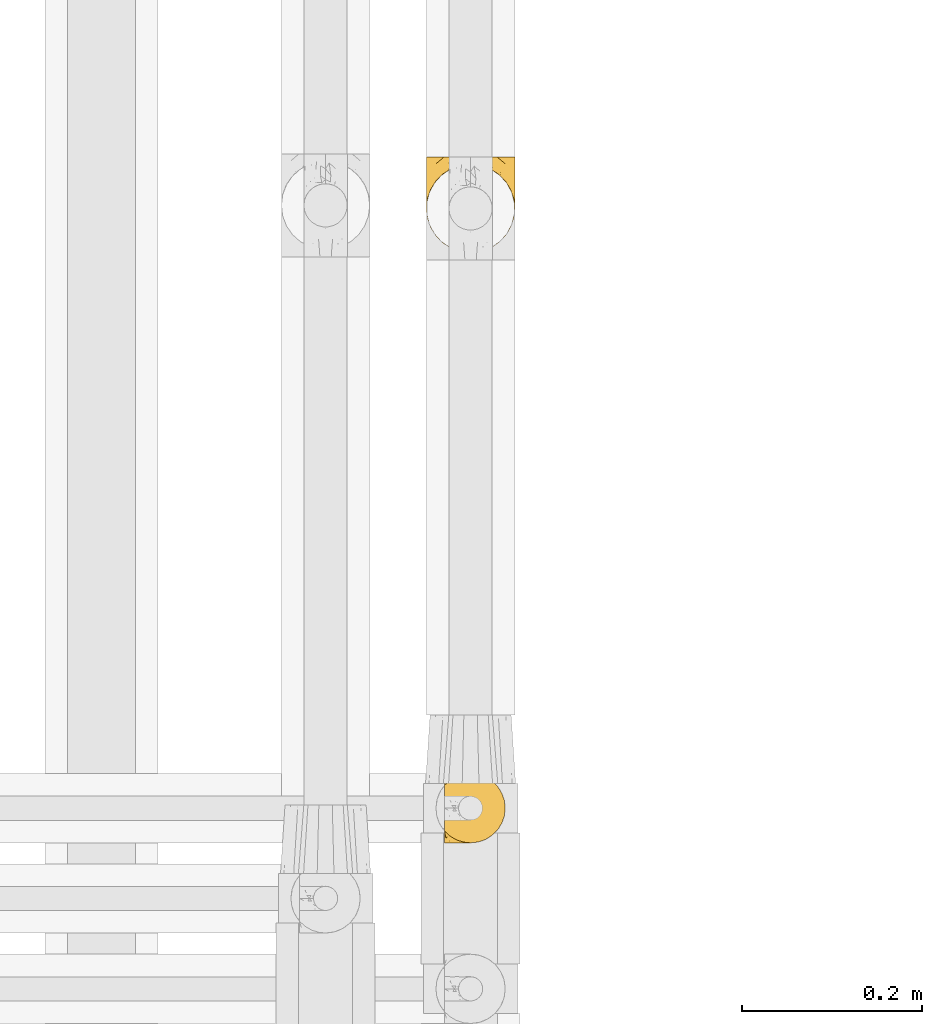
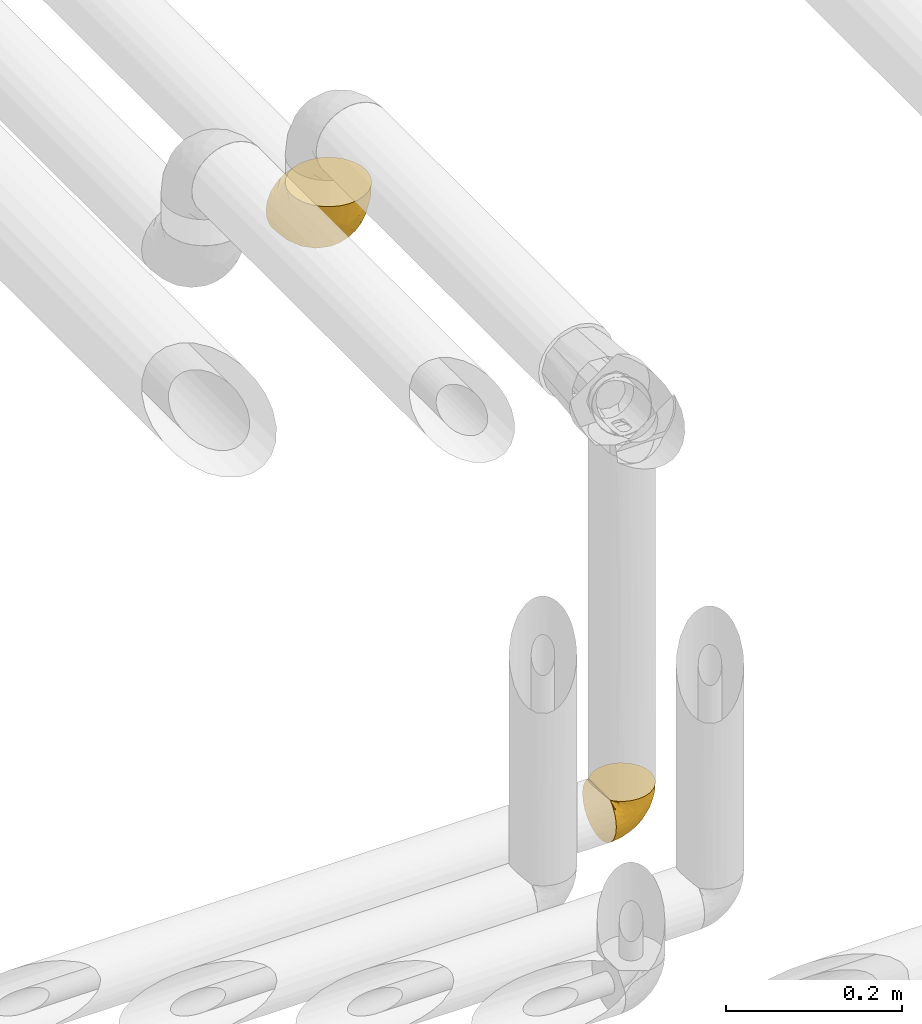
# One storey, part 346 of 827: 2 coverings.
"""IFC2X3 building model written with IfcOpenShell, lengths in millimetres."""

from ifc_helpers import new_model, entity, si_unit, converted_unit, derived_unit, direction, frame, origin, place, context, subcontext, project, spatial, faceted_brep, element, save


model = new_model("IFC2X3")

# Units and contexts
model_context = context("Model", 3, precision=0.01, world=origin(), true_north=direction((6.12303176911189e-17, 1.0)))
body_context = subcontext(model_context, "Body", "Model", "MODEL_VIEW")
ifc_project = project(units=[si_unit("LENGTHUNIT", "METRE", prefix="MILLI"), si_unit("AREAUNIT", "SQUARE_METRE"), si_unit("VOLUMEUNIT", "CUBIC_METRE"), converted_unit("PLANEANGLEUNIT", "DEGREE", entity("IfcRatioMeasure", 0.0174532925199433), si_unit("PLANEANGLEUNIT", "RADIAN"), dimensions=[0, 0, 0, 0, 0, 0, 0]), si_unit("MASSUNIT", "GRAM", prefix="KILO"), derived_unit("MASSDENSITYUNIT", [(si_unit("MASSUNIT", "GRAM", prefix="KILO"), 1), (si_unit("LENGTHUNIT", "METRE"), -3)]), derived_unit("MOMENTOFINERTIAUNIT", [(si_unit("LENGTHUNIT", "METRE"), 4)]), si_unit("TIMEUNIT", "SECOND"), si_unit("FREQUENCYUNIT", "HERTZ"), si_unit("THERMODYNAMICTEMPERATUREUNIT", "DEGREE_CELSIUS"), derived_unit("THERMALTRANSMITTANCEUNIT", [(si_unit("MASSUNIT", "GRAM", prefix="KILO"), 1), (si_unit("THERMODYNAMICTEMPERATUREUNIT", "KELVIN"), -1), (si_unit("TIMEUNIT", "SECOND"), -3)]), derived_unit("VOLUMETRICFLOWRATEUNIT", [(si_unit("LENGTHUNIT", "METRE"), 3), (si_unit("TIMEUNIT", "SECOND"), -1)]), derived_unit("MASSFLOWRATEUNIT", [(si_unit("MASSUNIT", "GRAM", prefix="KILO"), 1), (si_unit("TIMEUNIT", "SECOND"), -1)]), derived_unit("ROTATIONALFREQUENCYUNIT", [(si_unit("TIMEUNIT", "SECOND"), -1)]), si_unit("ELECTRICCURRENTUNIT", "AMPERE"), si_unit("ELECTRICVOLTAGEUNIT", "VOLT"), si_unit("POWERUNIT", "WATT"), si_unit("FORCEUNIT", "NEWTON", prefix="KILO"), si_unit("ILLUMINANCEUNIT", "LUX"), si_unit("LUMINOUSFLUXUNIT", "LUMEN"), si_unit("LUMINOUSINTENSITYUNIT", "CANDELA"), derived_unit("USERDEFINED", [(si_unit("MASSUNIT", "GRAM", prefix="KILO"), -1), (si_unit("LENGTHUNIT", "METRE"), -2), (si_unit("TIMEUNIT", "SECOND"), 3), (si_unit("LUMINOUSFLUXUNIT", "LUMEN"), 1)]), derived_unit("LINEARVELOCITYUNIT", [(si_unit("LENGTHUNIT", "METRE"), 1), (si_unit("TIMEUNIT", "SECOND"), -1)]), si_unit("PRESSUREUNIT", "PASCAL"), derived_unit("USERDEFINED", [(si_unit("LENGTHUNIT", "METRE"), -2), (si_unit("MASSUNIT", "GRAM", prefix="KILO"), 1), (si_unit("TIMEUNIT", "SECOND"), -2)]), derived_unit("LINEARFORCEUNIT", [(si_unit("MASSUNIT", "GRAM", prefix="KILO"), 1), (si_unit("LENGTHUNIT", "METRE"), 1), (si_unit("TIMEUNIT", "SECOND"), -2), (si_unit("LENGTHUNIT", "METRE"), -1)]), derived_unit("PLANARFORCEUNIT", [(si_unit("MASSUNIT", "GRAM", prefix="KILO"), 1), (si_unit("LENGTHUNIT", "METRE"), 1), (si_unit("TIMEUNIT", "SECOND"), -2), (si_unit("LENGTHUNIT", "METRE"), -2)])], contexts=[model_context])

# Site, building, storey
site_placement = place(None, origin())
site = spatial("IfcSite", under=ifc_project, at=site_placement, CompositionType="ELEMENT")
building_placement = place(site_placement, origin())
building = spatial("IfcBuilding", under=site, at=building_placement, CompositionType="ELEMENT")
storey_placement = place(building_placement, frame((0.0, 0.0, 28200.0)))
storey = spatial("IfcBuildingStorey", under=building, at=storey_placement, Name="08", CompositionType="ELEMENT", Elevation=28200.0)

# Coverings
covering_1_placement = place(storey_placement, frame((36598.95, 15549.99, 2959.95)))
element("IfcCovering", 1, at=covering_1_placement, inside=storey, Name=":ADSK_", ObjectType=":ADSK_", PredefinedType="INSULATION", context=body_context, shape_type="Brep", body=[
    faceted_brep([(47.38, 5.41, 69.15), (54.67, 9.99, 69.15), (60.76, 16.08, 69.15), (65.34, 23.37, 69.15), (68.18, 31.49, 69.15), (69.15, 40.05, 69.15), (68.18, 48.61, 69.15), (65.33, 56.73, 69.15), (60.75, 64.02, 69.15), (54.66, 70.11, 69.15), (47.37, 74.69, 69.15), (39.25, 77.53, 69.15), (30.7, 78.5, 69.15), (22.59, 77.63, 69.15), (14.86, 75.08, 69.15), (7.84, 70.97, 69.15), (1.85, 65.47, 69.15), (1.85, 63.27, 69.15), (1.85, 61.53, 69.15), (1.85, 59.57, 69.15), (1.85, 57.6, 69.15), (1.85, 55.63, 69.15), (1.85, 53.67, 69.15), (1.85, 51.7, 69.15), (1.85, 49.73, 69.15), (1.85, 47.54, 69.15), (1.85, 45.34, 69.15), (1.85, 43.15, 69.15), (1.85, 40.96, 69.15), (1.85, 38.76, 69.15), (1.85, 36.57, 69.15), (1.85, 34.37, 69.15), (1.85, 32.18, 69.15), (1.85, 29.98, 69.15), (1.85, 27.79, 69.15), (1.85, 25.6, 69.15), (1.85, 23.4, 69.15), (1.85, 21.21, 69.15), (1.85, 19.01, 69.15), (1.85, 16.82, 69.15), (1.85, 14.62, 69.15), (7.85, 9.12, 69.15), (14.88, 5.0, 69.15), (22.61, 2.46, 69.15), (30.7, 1.6, 69.15), (39.26, 2.56, 69.15), (1.6, 65.47, 68.89), (1.6, 70.97, 62.89), (1.6, 75.09, 55.87), (1.6, 77.63, 48.14), (1.6, 78.5, 40.05), (1.6, 77.19, 30.09), (1.6, 73.34, 20.82), (1.6, 67.23, 12.86), (1.6, 59.27, 6.75), (1.6, 50.0, 2.91), (1.6, 40.05, 1.6), (1.6, 30.09, 2.91), (1.6, 20.82, 6.75), (1.6, 12.86, 12.86), (1.6, 6.75, 20.82), (1.6, 2.91, 30.09), (1.6, 1.6, 40.05), (1.6, 2.46, 48.14), (1.6, 5.0, 55.87), (1.6, 9.12, 62.89), (1.6, 14.62, 68.89), (1.6, 16.82, 68.89), (1.6, 17.8, 68.89), (1.6, 19.39, 68.89), (1.6, 20.98, 68.89), (1.6, 22.57, 68.89), (1.6, 24.16, 68.89), (1.6, 25.75, 68.89), (1.6, 27.33, 68.89), (1.6, 28.92, 68.89), (1.6, 30.51, 68.89), (1.6, 32.1, 68.89), (1.6, 33.69, 68.89), (1.6, 35.28, 68.89), (1.6, 36.87, 68.89), (1.6, 38.46, 68.89), (1.6, 40.05, 68.89), (1.6, 41.63, 68.89), (1.6, 43.22, 68.89), (1.6, 44.81, 68.89), (1.6, 46.4, 68.89), (1.6, 47.99, 68.89), (1.6, 49.58, 68.89), (1.6, 51.17, 68.89), (1.6, 52.76, 68.89), (1.6, 54.72, 68.89), (1.6, 56.69, 68.89), (1.6, 58.88, 68.89), (1.6, 61.08, 68.89), (1.6, 63.27, 68.89), (1.78, 37.77, 68.97), (1.77, 36.07, 68.96), (1.78, 32.96, 68.97), (1.77, 31.36, 68.97), (1.79, 56.52, 68.98), (1.78, 54.96, 68.97), (1.76, 18.75, 68.96), (1.77, 58.07, 68.96), (1.77, 50.37, 68.96), (1.76, 23.36, 68.96), (1.77, 24.95, 68.96), (1.77, 42.43, 68.96), (1.8, 15.97, 69.0), (1.76, 51.96, 68.96), (1.77, 53.47, 68.96), (1.78, 48.63, 68.97), (1.77, 63.93, 68.96), (1.77, 40.93, 68.96), (1.76, 29.72, 68.96), (1.77, 62.4, 68.97), (1.78, 60.92, 68.97), (1.77, 17.31, 68.97), (1.77, 21.74, 68.96), (1.77, 34.56, 68.96), (1.78, 20.18, 68.97), (1.77, 14.62, 68.97), (1.8, 14.62, 69.02), (1.82, 14.62, 69.08), (1.77, 65.47, 68.97), (1.72, 65.47, 68.94), (1.66, 65.47, 68.92), (1.76, 59.5, 68.96), (1.77, 47.1, 68.96), (1.76, 45.61, 68.95), (1.77, 28.18, 68.96), (1.66, 14.62, 68.92), (1.72, 14.62, 68.94), (1.78, 26.61, 68.98), (1.82, 65.47, 69.08), (1.8, 65.47, 69.02), (1.77, 39.32, 68.96), (1.78, 44.12, 68.97), (3.72, 72.26, 61.33), (7.41, 76.57, 53.1), (6.13, 71.77, 63.33), (21.47, 78.5, 49.27), (19.34, 77.9, 55.53), (26.8, 78.5, 54.6), (8.87, 78.5, 41.99), (9.2, 75.52, 57.07), (12.79, 76.13, 57.95), (14.62, 77.81, 51.56), (7.34, 78.5, 41.58), (5.33, 72.4, 61.7), (17.64, 76.56, 63.33), (7.7, 71.77, 65.0), (9.41, 72.25, 67.02), (28.75, 78.5, 61.87), (16.15, 78.5, 43.94), (14.14, 75.75, 61.21), (29.16, 78.5, 63.4), (57.02, 50.46, 33.11), (64.92, 52.75, 52.82), (64.0, 40.05, 43.3), (11.92, 77.7, 33.73), (19.16, 77.66, 36.52), (28.65, 71.02, 24.87), (24.62, 63.45, 14.17), (15.19, 70.55, 18.43), (18.36, 75.57, 28.67), (9.2, 75.57, 26.0), (46.98, 72.61, 49.25), (50.24, 72.61, 59.72), (56.1, 67.24, 55.1), (28.97, 77.74, 44.72), (54.46, 57.43, 34.15), (21.34, 47.19, 5.25), (18.4, 54.76, 6.75), (66.44, 40.05, 55.54), (12.07, 63.45, 10.47), (45.49, 60.1, 25.49), (50.57, 63.72, 35.53), (36.04, 76.83, 48.22), (42.07, 76.34, 58.71), (62.12, 60.51, 57.42), (37.37, 72.59, 34.84), (29.39, 76.05, 36.87), (53.59, 66.15, 45.01), (58.06, 60.51, 44.4), (49.27, 51.88, 23.96), (29.63, 55.34, 11.2), (33.21, 48.67, 10.56), (40.1, 53.89, 16.81), (44.08, 46.73, 17.38), (49.36, 40.05, 21.38), (56.68, 40.05, 32.34), (15.2, 40.05, 4.3), (35.57, 63.95, 20.65), (41.7, 67.24, 29.66), (46.4, 69.62, 39.6), (41.41, 73.6, 42.55), (27.45, 40.05, 6.74), (38.4, 40.05, 14.06), (12.99, 4.52, 26.84), (21.33, 32.72, 5.28), (42.89, 27.18, 18.52), (57.04, 29.63, 33.13), (56.11, 12.86, 55.1), (62.13, 19.59, 57.43), (21.89, 9.54, 20.72), (16.62, 16.64, 11.46), (32.9, 17.48, 17.69), (46.99, 7.49, 49.26), (50.25, 7.49, 59.73), (42.08, 3.75, 58.71), (49.91, 20.75, 29.72), (15.6, 2.33, 35.35), (16.15, 1.6, 43.94), (8.87, 1.6, 41.99), (29.16, 1.6, 63.4), (13.16, 26.94, 4.93), (10.83, 9.54, 17.46), (33.8, 31.21, 10.94), (25.02, 25.33, 8.92), (64.92, 27.35, 52.83), (32.83, 8.17, 29.34), (20.56, 4.3, 30.26), (58.07, 19.59, 44.4), (21.46, 2.23, 39.06), (28.1, 2.45, 43.06), (26.8, 1.6, 54.6), (21.47, 1.6, 49.27), (51.29, 12.86, 42.69), (36.04, 3.27, 48.2), (28.75, 1.6, 61.87), (8.45, 2.29, 33.44), (41.73, 12.86, 29.67), (39.27, 6.89, 38.5), (33.56, 12.43, 23.35), (27.29, 4.1, 34.97), (7.41, 3.53, 53.1), (3.51, 6.88, 59.68), (4.68, 8.16, 62.19), (5.52, 9.02, 64.11), (8.75, 5.0, 57.97), (12.79, 3.96, 57.95), (17.65, 3.52, 63.33), (13.9, 2.4, 51.77), (9.42, 7.83, 67.02), (7.68, 8.32, 64.98), (19.33, 2.19, 55.53), (14.13, 4.34, 61.22)], [[[0, 1, 2, 3, 4, 5, 6, 7, 8, 9, 10, 11, 12, 13, 14, 15, 16, 17, 18, 19, 20, 21, 22, 23, 24, 25, 26, 27, 28, 29, 30, 31, 32, 33, 34, 35, 36, 37, 38, 39, 40, 41, 42, 43, 44, 45]], [[46, 47, 48, 49, 50, 51, 52, 53, 54, 55, 56, 57, 58, 59, 60, 61, 62, 63, 64, 65, 66, 67, 68, 69, 70, 71, 72, 73, 74, 75, 76, 77, 78, 79, 80, 81, 82, 83, 84, 85, 86, 87, 88, 89, 90, 91, 92, 93, 94, 95]], [[96, 97, 30]], [[98, 77, 99]], [[100, 101, 21]], [[69, 68, 102]], [[20, 19, 103]], [[24, 23, 104]], [[20, 103, 100]], [[72, 105, 106]], [[84, 83, 107]], [[89, 88, 104]], [[108, 67, 66]], [[109, 110, 90]], [[111, 25, 24]], [[112, 17, 16]], [[82, 113, 83]], [[109, 23, 22]], [[114, 76, 75]], [[105, 36, 106]], [[104, 111, 24]], [[18, 115, 116]], [[97, 96, 80]], [[67, 108, 117]], [[105, 71, 118]], [[31, 97, 119]], [[102, 120, 69]], [[108, 121, 122, 123, 40]], [[112, 95, 115]], [[17, 115, 18]], [[94, 116, 115]], [[117, 68, 67]], [[38, 117, 39]], [[112, 124, 125, 126, 46]], [[17, 112, 115]], [[70, 120, 118]], [[39, 117, 108]], [[120, 38, 37]], [[120, 37, 118]], [[120, 70, 69]], [[116, 94, 127]], [[128, 86, 129]], [[117, 38, 102]], [[74, 130, 75]], [[99, 33, 32]], [[115, 95, 94]], [[39, 108, 40]], [[108, 66, 131, 132, 121]], [[105, 72, 71]], [[118, 37, 36]], [[71, 70, 118]], [[35, 106, 36]], [[36, 105, 118]], [[35, 133, 106]], [[74, 73, 133]], [[106, 133, 73]], [[99, 114, 33]], [[133, 35, 34]], [[73, 72, 106]], [[95, 112, 46]], [[112, 16, 134, 135, 124]], [[130, 114, 75]], [[99, 76, 114]], [[114, 130, 33]], [[34, 33, 130]], [[78, 77, 98]], [[98, 119, 78]], [[130, 133, 34]], [[133, 130, 74]], [[79, 97, 80]], [[98, 99, 32]], [[98, 32, 31]], [[77, 76, 99]], [[97, 79, 119]], [[136, 96, 29]], [[30, 97, 31]], [[136, 29, 28]], [[81, 80, 96]], [[29, 96, 30]], [[31, 119, 98]], [[119, 79, 78]], [[96, 136, 81]], [[82, 81, 136]], [[113, 107, 83]], [[84, 107, 137]], [[107, 27, 137]], [[113, 28, 107]], [[27, 107, 28]], [[85, 84, 137]], [[137, 27, 26]], [[113, 136, 28]], [[136, 113, 82]], [[109, 89, 104]], [[86, 85, 129]], [[89, 109, 90]], [[111, 87, 128]], [[26, 129, 137]], [[88, 111, 104]], [[25, 111, 128]], [[22, 110, 109]], [[23, 109, 104]], [[110, 91, 90]], [[100, 92, 101]], [[110, 22, 101]], [[91, 110, 101]], [[116, 19, 18]], [[111, 88, 87]], [[127, 103, 19]], [[25, 128, 26]], [[86, 128, 87]], [[128, 129, 26]], [[137, 129, 85]], [[120, 102, 38]], [[117, 102, 68]], [[91, 101, 92]], [[21, 101, 22]], [[93, 92, 103]], [[100, 21, 20]], [[100, 103, 92]], [[127, 93, 103]], [[93, 127, 94]], [[116, 127, 19]], [[126, 138, 47]], [[48, 138, 139]], [[140, 125, 124]], [[141, 142, 143]], [[144, 49, 139]], [[145, 140, 146]], [[48, 139, 49]], [[139, 145, 147]], [[49, 144, 148, 50]], [[126, 125, 149]], [[14, 13, 150]], [[151, 146, 140]], [[149, 140, 145]], [[152, 151, 135]], [[152, 14, 150]], [[16, 15, 134]], [[13, 153, 150]], [[124, 151, 140]], [[141, 147, 142]], [[14, 152, 15]], [[15, 152, 134]], [[47, 46, 126]], [[139, 154, 144]], [[138, 48, 47]], [[125, 140, 149]], [[135, 134, 152]], [[146, 155, 142]], [[145, 146, 147]], [[149, 139, 138]], [[147, 141, 154]], [[147, 146, 142]], [[139, 147, 154]], [[139, 149, 145]], [[149, 138, 126]], [[155, 146, 151]], [[150, 143, 142]], [[152, 155, 151]], [[150, 142, 155]], [[13, 12, 156, 153]], [[153, 143, 150]], [[152, 150, 155]], [[151, 124, 135]], [[157, 158, 159]], [[160, 154, 161]], [[162, 163, 164]], [[165, 166, 160]], [[167, 168, 169]], [[141, 170, 161]], [[156, 12, 11]], [[158, 157, 171]], [[172, 55, 173]], [[158, 6, 174]], [[175, 54, 53]], [[52, 166, 164]], [[52, 164, 53]], [[54, 175, 173]], [[166, 52, 51]], [[176, 177, 171]], [[178, 143, 179]], [[156, 11, 179]], [[8, 7, 180]], [[169, 9, 8]], [[179, 143, 153, 156]], [[179, 11, 10]], [[168, 179, 10]], [[181, 162, 182]], [[179, 167, 178]], [[183, 184, 177]], [[183, 169, 184]], [[176, 171, 185]], [[172, 186, 187]], [[158, 7, 6]], [[159, 158, 174]], [[184, 180, 158]], [[54, 173, 55]], [[180, 169, 8]], [[188, 189, 187]], [[9, 168, 10]], [[186, 188, 187]], [[190, 157, 159, 191]], [[55, 172, 192]], [[176, 193, 194]], [[161, 170, 182]], [[162, 164, 165]], [[175, 164, 163]], [[51, 50, 148]], [[167, 195, 196]], [[178, 182, 170]], [[6, 5, 174]], [[158, 180, 7]], [[169, 180, 184]], [[169, 168, 9]], [[179, 168, 167]], [[182, 162, 165]], [[162, 194, 193]], [[161, 165, 160]], [[195, 181, 196]], [[192, 172, 197]], [[192, 56, 55]], [[189, 190, 198]], [[198, 197, 187]], [[172, 187, 197]], [[185, 189, 188]], [[198, 187, 189]], [[186, 172, 173]], [[173, 163, 186]], [[193, 186, 163]], [[176, 185, 188]], [[185, 157, 190]], [[188, 186, 193]], [[177, 176, 194]], [[188, 193, 176]], [[162, 193, 163]], [[195, 177, 194]], [[171, 177, 184]], [[181, 195, 194]], [[183, 167, 169]], [[162, 181, 194]], [[196, 182, 178]], [[158, 171, 184]], [[171, 157, 185]], [[177, 195, 183]], [[167, 183, 195]], [[182, 196, 181]], [[178, 170, 143]], [[178, 167, 196]], [[164, 175, 53]], [[173, 175, 163]], [[160, 51, 148]], [[164, 166, 165]], [[51, 160, 166]], [[160, 148, 144, 154]], [[141, 161, 154]], [[182, 165, 161]], [[190, 189, 185]], [[143, 170, 141]], [[60, 199, 61]], [[197, 200, 192]], [[201, 190, 202]], [[200, 57, 192]], [[203, 204, 2]], [[205, 206, 207]], [[208, 209, 210]], [[211, 207, 201]], [[212, 213, 214]], [[45, 215, 210]], [[216, 206, 58]], [[45, 44, 215]], [[59, 217, 60]], [[60, 217, 199]], [[0, 45, 210]], [[218, 201, 219]], [[202, 159, 220]], [[205, 221, 222]], [[223, 204, 203]], [[1, 203, 2]], [[57, 200, 216]], [[220, 3, 204]], [[220, 174, 4]], [[1, 0, 209]], [[212, 224, 213]], [[225, 226, 227]], [[228, 223, 203]], [[208, 210, 229]], [[210, 226, 229]], [[3, 220, 4]], [[58, 206, 59]], [[209, 203, 1]], [[202, 220, 223]], [[228, 203, 208]], [[202, 211, 201]], [[3, 2, 204]], [[202, 190, 191, 159]], [[210, 215, 230, 226]], [[199, 212, 231]], [[232, 233, 221]], [[233, 208, 229]], [[207, 206, 219]], [[217, 206, 205]], [[227, 224, 225]], [[233, 232, 228]], [[201, 207, 219]], [[234, 232, 221]], [[218, 219, 200]], [[202, 223, 211]], [[174, 220, 159]], [[174, 5, 4]], [[61, 231, 62]], [[220, 204, 223]], [[210, 209, 0]], [[203, 209, 208]], [[225, 233, 229]], [[224, 227, 213]], [[221, 233, 235]], [[57, 56, 192]], [[198, 218, 197]], [[200, 219, 216]], [[201, 198, 190]], [[197, 218, 200]], [[198, 201, 218]], [[206, 216, 219]], [[58, 57, 216]], [[231, 212, 214]], [[222, 212, 199]], [[228, 211, 223]], [[207, 211, 232]], [[62, 231, 214]], [[199, 231, 61]], [[233, 228, 208]], [[211, 228, 232]], [[222, 221, 235]], [[234, 205, 207]], [[206, 217, 59]], [[199, 217, 205]], [[205, 222, 199]], [[224, 222, 235]], [[222, 224, 212]], [[224, 235, 225]], [[233, 225, 235]], [[226, 225, 229]], [[205, 234, 221]], [[207, 232, 234]], [[63, 214, 236]], [[214, 213, 236]], [[214, 63, 62]], [[237, 236, 238]], [[238, 132, 131]], [[236, 237, 64]], [[239, 240, 241]], [[63, 236, 64]], [[131, 66, 65]], [[237, 131, 65]], [[242, 230, 43]], [[237, 65, 64]], [[239, 121, 132]], [[42, 242, 43]], [[241, 240, 243]], [[41, 123, 244]], [[43, 230, 215, 44]], [[244, 122, 245]], [[227, 246, 243]], [[241, 247, 245]], [[121, 239, 245]], [[41, 40, 123]], [[132, 238, 239]], [[244, 42, 41]], [[131, 237, 238]], [[240, 239, 238]], [[245, 239, 241]], [[247, 241, 246]], [[247, 244, 245]], [[238, 236, 240]], [[243, 236, 213]], [[236, 243, 240]], [[227, 226, 246]], [[243, 213, 227]], [[242, 246, 226]], [[243, 246, 241]], [[246, 242, 247]], [[244, 247, 242]], [[242, 226, 230]], [[42, 244, 242]], [[122, 244, 123]], [[122, 121, 245]]]),
])
covering_2_placement = place(storey_placement, frame((36578.9, 16204.74, 3349.15)))
element("IfcCovering", 2, at=covering_2_placement, inside=storey, Name=":ADSK_", ObjectType=":ADSK_", PredefinedType="INSULATION", context=body_context, shape_type="Brep", body=[
    faceted_brep([(1.6, 50.75, 107.75), (2.83, 39.8, 107.75), (6.47, 29.41, 107.75), (12.32, 20.09, 107.75), (20.11, 12.31, 107.75), (29.43, 6.46, 107.75), (39.81, 2.83, 107.75), (50.75, 1.6, 107.75), (61.69, 2.83, 107.75), (72.08, 6.47, 107.75), (81.4, 12.32, 107.75), (89.18, 20.11, 107.75), (95.03, 29.43, 107.75), (98.66, 39.81, 107.75), (99.9, 50.75, 107.75), (99.25, 56.45, 107.75), (98.66, 61.69, 107.75), (96.84, 66.88, 107.75), (95.02, 72.08, 107.75), (89.17, 81.4, 107.75), (81.38, 89.18, 107.75), (72.06, 95.03, 107.75), (61.68, 98.66, 107.75), (50.75, 99.9, 107.75), (39.8, 98.66, 107.75), (29.41, 95.02, 107.75), (20.09, 89.17, 107.75), (12.31, 81.38, 107.75), (6.46, 72.06, 107.75), (4.64, 66.87, 107.75), (2.83, 61.68, 107.75), (2.24, 56.45, 107.75), (1.92, 53.6, 107.75), (63.47, 107.75, 98.22), (75.32, 107.75, 93.31), (80.41, 107.75, 89.4), (85.5, 107.75, 85.5), (89.4, 107.75, 80.41), (93.31, 107.75, 75.32), (95.77, 107.75, 69.39), (98.22, 107.75, 63.47), (99.14, 107.75, 56.48), (99.52, 107.75, 53.61), (99.9, 107.75, 50.75), (98.22, 107.75, 38.02), (93.31, 107.75, 26.17), (85.5, 107.75, 15.99), (75.32, 107.75, 8.18), (63.47, 107.75, 3.27), (50.75, 107.75, 1.6), (38.02, 107.75, 3.27), (26.17, 107.75, 8.18), (15.99, 107.75, 15.99), (8.18, 107.75, 26.17), (3.27, 107.75, 38.02), (1.6, 107.75, 50.75), (2.35, 107.75, 56.48), (3.27, 107.75, 63.47), (5.73, 107.75, 69.39), (8.18, 107.75, 75.32), (12.09, 107.75, 80.41), (15.99, 107.75, 85.5), (21.08, 107.75, 89.4), (26.17, 107.75, 93.31), (38.02, 107.75, 98.22), (50.75, 107.75, 99.9), (42.18, 39.38, 27.53), (28.42, 49.75, 25.32), (37.78, 57.38, 16.29), (50.75, 74.94, 6.79), (42.85, 85.97, 4.51), (50.75, 95.66, 3.51), (24.75, 67.82, 17.47), (33.81, 83.09, 7.6), (22.57, 89.16, 12.27), (7.18, 37.01, 70.89), (2.73, 43.46, 87.17), (3.09, 51.79, 67.3), (6.92, 85.58, 31.65), (11.58, 62.84, 33.58), (5.17, 62.77, 47.23), (2.71, 88.17, 43.26), (1.6, 85.93, 55.08), (1.6, 91.42, 53.99), (1.6, 96.91, 52.9), (1.6, 99.62, 52.36), (1.6, 102.33, 51.82), (14.18, 82.57, 21.5), (5.88, 32.75, 89.94), (41.06, 13.79, 60.45), (36.25, 6.77, 83.0), (28.62, 16.46, 64.79), (1.6, 55.08, 85.93), (1.6, 58.17, 81.31), (1.6, 61.26, 76.69), (1.6, 64.35, 72.06), (1.6, 67.44, 67.44), (10.85, 24.18, 88.74), (38.35, 23.37, 45.98), (9.6, 49.76, 47.13), (26.24, 9.84, 89.4), (50.75, 3.51, 95.66), (19.31, 55.75, 28.5), (16.41, 42.34, 42.81), (24.56, 37.78, 38.28), (50.75, 21.87, 45.35), (50.75, 33.61, 33.61), (18.47, 17.1, 82.57), (1.6, 51.28, 105.04), (1.6, 51.82, 102.33), (1.6, 52.9, 96.91), (1.6, 53.99, 91.42), (14.36, 28.01, 65.92), (20.64, 28.99, 53.11), (2.32, 69.9, 54.37), (50.75, 6.79, 74.94), (1.6, 72.06, 64.35), (1.6, 76.69, 61.26), (1.6, 81.31, 58.17), (50.75, 45.35, 21.87), (33.88, 34.79, 34.79), (29.24, 25.72, 48.48), (50.75, 14.33, 60.15), (50.75, 60.15, 14.33), (2.8, 62.38, 99.07), (2.48, 100.57, 60.55), (2.7, 91.06, 64.18), (3.2, 97.66, 64.36), (32.98, 97.55, 103.17), (24.67, 93.65, 101.69), (2.95, 66.85, 87.75), (2.19, 61.93, 89.38), (17.92, 101.4, 88.34), (12.02, 100.07, 82.14), (25.73, 101.36, 94.51), (16.63, 95.94, 89.64), (25.6, 96.3, 98.41), (36.72, 101.98, 99.71), (10.66, 85.88, 89.37), (6.87, 78.88, 88.21), (11.12, 82.8, 95.2), (10.31, 102.58, 79.14), (12.84, 82.88, 101.22), (17.38, 88.57, 99.41), (9.74, 88.67, 84.72), (4.63, 69.08, 97.47), (50.75, 102.19, 102.19), (42.52, 100.06, 104.02), (3.12, 70.56, 82.66), (17.58, 91.07, 95.42), (3.97, 77.56, 78.67), (5.94, 96.59, 72.69), (2.73, 86.38, 66.46), (6.23, 91.79, 75.3), (3.45, 81.71, 72.74), (10.84, 94.11, 82.93), (7.98, 76.09, 99.27), (7.33, 76.91, 93.51), (2.39, 81.44, 67.35), (75.76, 101.37, 94.51), (90.65, 94.12, 82.94), (83.57, 101.41, 88.33), (84.85, 95.96, 89.64), (71.05, 96.22, 103.62), (98.54, 66.85, 87.74), (99.3, 61.94, 89.38), (99.9, 58.17, 81.31), (96.86, 69.1, 97.47), (84.1, 88.58, 99.41), (99.9, 96.91, 52.9), (99.9, 102.33, 51.82), (99.9, 105.04, 51.28), (88.63, 82.9, 101.21), (90.36, 82.82, 95.19), (98.29, 97.66, 64.36), (95.55, 96.59, 72.69), (89.47, 100.07, 82.13), (95.26, 91.79, 75.3), (91.18, 102.58, 79.14), (93.49, 76.13, 99.28), (94.15, 76.93, 93.51), (99.01, 100.57, 60.55), (98.76, 86.38, 66.46), (98.85, 90.86, 63.96), (99.9, 52.9, 96.91), (98.69, 62.39, 99.06), (64.78, 101.98, 99.7), (99.9, 91.42, 53.99), (99.9, 85.93, 55.08), (62.91, 99.49, 103.3), (99.9, 51.82, 102.33), (99.9, 52.36, 99.62), (99.9, 61.26, 76.69), (98.37, 70.56, 82.66), (83.9, 91.09, 95.42), (99.9, 64.35, 72.06), (97.51, 77.6, 78.68), (94.62, 78.89, 88.2), (98.04, 81.71, 72.75), (91.73, 88.69, 84.74), (99.9, 53.99, 91.42), (99.9, 55.08, 85.93), (75.87, 96.31, 98.41), (90.83, 85.9, 89.37), (99.1, 81.45, 67.35), (99.9, 76.69, 61.26), (99.9, 81.31, 58.17), (99.9, 72.06, 64.35), (99.9, 67.44, 67.44), (99.09, 69.6, 54.08), (58.64, 85.97, 4.51), (87.31, 82.57, 21.5), (89.93, 63.16, 33.43), (82.22, 55.81, 28.5), (76.74, 67.81, 17.47), (73.12, 49.73, 25.36), (95.54, 32.55, 90.18), (98.7, 43.23, 86.97), (98.79, 88.17, 43.26), (63.71, 57.38, 16.29), (67.68, 83.08, 7.6), (78.92, 89.16, 12.27), (94.57, 85.58, 31.65), (72.88, 16.46, 64.79), (65.25, 6.77, 83.0), (60.44, 13.8, 60.44), (76.94, 37.71, 38.35), (67.61, 34.8, 34.8), (94.38, 36.83, 71.54), (59.31, 39.38, 27.53), (83.03, 17.12, 82.57), (90.66, 24.19, 88.74), (80.8, 28.89, 53.19), (72.22, 25.69, 48.49), (98.39, 51.77, 67.28), (92.31, 45.66, 52.32), (63.11, 23.39, 45.94), (75.27, 9.85, 89.4), (87.15, 28.11, 65.75), (96.03, 62.27, 46.73), (85.1, 42.35, 42.82)], [[[0, 1, 2, 3, 4, 5, 6, 7, 8, 9, 10, 11, 12, 13, 14, 15, 16, 17, 18, 19, 20, 21, 22, 23, 24, 25, 26, 27, 28, 29, 30, 31, 32]], [[33, 34, 35, 36, 37, 38, 39, 40, 41, 42, 43, 44, 45, 46, 47, 48, 49, 50, 51, 52, 53, 54, 55, 56, 57, 58, 59, 60, 61, 62, 63, 64, 65]], [[66, 67, 68]], [[69, 70, 71]], [[68, 72, 73]], [[73, 72, 74]], [[75, 76, 77]], [[78, 79, 80]], [[51, 50, 73]], [[81, 82, 83, 84, 85, 86, 55]], [[52, 87, 53]], [[74, 52, 51]], [[2, 1, 88]], [[89, 90, 91]], [[77, 92, 93, 94, 95, 96]], [[55, 54, 81]], [[78, 53, 87]], [[5, 90, 6]], [[88, 76, 75]], [[97, 3, 2]], [[89, 91, 98]], [[99, 80, 79]], [[90, 5, 100]], [[74, 87, 52]], [[100, 5, 4]], [[90, 101, 6]], [[79, 102, 103]], [[102, 67, 104]], [[105, 98, 106]], [[107, 4, 3]], [[76, 0, 108, 109, 110, 111, 92]], [[107, 112, 113]], [[114, 77, 96]], [[89, 115, 90]], [[114, 96, 116, 117, 118, 82]], [[75, 97, 88]], [[119, 66, 68]], [[50, 71, 70]], [[100, 91, 90]], [[99, 77, 80]], [[102, 104, 103]], [[97, 107, 3]], [[80, 81, 78]], [[107, 97, 112]], [[68, 73, 70]], [[66, 98, 120]], [[78, 81, 54]], [[114, 81, 80]], [[53, 78, 54]], [[78, 87, 79]], [[102, 87, 72]], [[79, 103, 99]], [[4, 107, 100]], [[91, 100, 107]], [[88, 97, 2]], [[112, 97, 75]], [[99, 112, 75]], [[103, 104, 113]], [[91, 121, 98]], [[89, 105, 122, 115]], [[101, 90, 115]], [[101, 7, 6]], [[88, 1, 76]], [[0, 76, 1]], [[92, 77, 76]], [[73, 74, 51]], [[87, 74, 72]], [[81, 114, 82]], [[77, 114, 80]], [[87, 102, 79]], [[67, 102, 72]], [[68, 67, 72]], [[67, 120, 104]], [[120, 121, 104]], [[104, 121, 113]], [[121, 120, 98]], [[91, 107, 113]], [[91, 113, 121]], [[103, 113, 112]], [[106, 98, 66]], [[105, 89, 98]], [[106, 66, 119]], [[67, 66, 120]], [[68, 69, 123, 119]], [[50, 49, 71]], [[50, 70, 73]], [[112, 99, 103]], [[77, 99, 75]], [[69, 68, 70]], [[29, 124, 110]], [[84, 83, 125]], [[126, 82, 118]], [[59, 58, 127]], [[25, 128, 129]], [[130, 93, 131]], [[132, 62, 133]], [[134, 135, 136]], [[137, 65, 64]], [[64, 134, 137]], [[138, 139, 140]], [[111, 110, 124, 92]], [[134, 136, 137]], [[134, 64, 63]], [[141, 61, 60]], [[125, 58, 57]], [[142, 143, 140]], [[142, 26, 143]], [[127, 83, 82]], [[28, 124, 29]], [[108, 0, 32, 31, 30, 110, 109]], [[30, 29, 110]], [[135, 144, 138]], [[28, 145, 124]], [[57, 56, 55, 86, 85, 84]], [[146, 147, 23]], [[24, 23, 147]], [[25, 143, 26]], [[95, 94, 148]], [[24, 128, 25]], [[149, 138, 143]], [[124, 145, 131]], [[127, 58, 125]], [[150, 148, 139]], [[127, 126, 151]], [[151, 59, 127]], [[152, 151, 126]], [[153, 154, 155]], [[153, 133, 141]], [[145, 28, 27]], [[142, 156, 27]], [[157, 148, 130]], [[61, 133, 62]], [[134, 132, 135]], [[147, 128, 24]], [[65, 137, 146]], [[146, 137, 147]], [[128, 137, 136]], [[137, 128, 147]], [[128, 136, 129]], [[149, 129, 136]], [[25, 129, 143]], [[158, 152, 117]], [[152, 118, 117]], [[153, 151, 152]], [[158, 116, 154]], [[144, 150, 138]], [[153, 152, 158]], [[133, 153, 155]], [[133, 155, 132]], [[60, 151, 141]], [[135, 132, 155]], [[134, 63, 132]], [[144, 135, 155]], [[135, 138, 149]], [[155, 154, 144]], [[150, 154, 96]], [[154, 150, 144]], [[148, 94, 130]], [[82, 126, 127]], [[118, 152, 126]], [[150, 96, 95]], [[139, 148, 157]], [[150, 95, 148]], [[93, 92, 131]], [[130, 145, 156]], [[130, 94, 93]], [[84, 125, 57]], [[127, 125, 83]], [[140, 139, 157]], [[150, 139, 138]], [[140, 157, 142]], [[138, 140, 143]], [[156, 142, 157]], [[27, 26, 142]], [[130, 156, 157]], [[145, 27, 156]], [[132, 63, 62]], [[124, 131, 92]], [[130, 131, 145]], [[129, 149, 143]], [[135, 149, 136]], [[141, 133, 61]], [[60, 59, 151]], [[141, 151, 153]], [[116, 96, 154]], [[153, 158, 154]], [[158, 117, 116]], [[34, 33, 159]], [[160, 161, 162]], [[22, 21, 163]], [[164, 165, 166]], [[19, 18, 167]], [[168, 21, 20]], [[42, 41, 40, 169, 170, 171, 43]], [[172, 173, 168]], [[174, 38, 175]], [[176, 177, 178]], [[179, 164, 180]], [[40, 181, 169]], [[182, 183, 175]], [[17, 184, 185]], [[65, 146, 186]], [[187, 174, 188]], [[23, 22, 189]], [[174, 39, 38]], [[15, 14, 190, 191, 184, 16]], [[181, 40, 39]], [[192, 193, 164]], [[194, 163, 168]], [[33, 186, 159]], [[180, 173, 172]], [[195, 196, 193]], [[18, 185, 167]], [[173, 180, 197]], [[198, 199, 196]], [[200, 201, 185, 184]], [[184, 17, 16]], [[18, 17, 185]], [[202, 159, 186]], [[194, 168, 203]], [[189, 163, 202]], [[204, 205, 182]], [[187, 181, 174]], [[160, 177, 176]], [[206, 183, 182]], [[206, 182, 205]], [[201, 165, 185]], [[165, 164, 167]], [[172, 179, 180]], [[202, 194, 162]], [[176, 161, 160]], [[65, 186, 33]], [[163, 189, 22]], [[175, 177, 182]], [[174, 183, 188]], [[177, 198, 204]], [[199, 160, 162]], [[198, 207, 204]], [[175, 38, 37]], [[198, 177, 160]], [[178, 177, 175]], [[176, 35, 161]], [[34, 159, 161]], [[162, 161, 159]], [[202, 162, 159]], [[199, 162, 203]], [[196, 199, 203]], [[198, 160, 199]], [[193, 197, 180]], [[208, 198, 196]], [[188, 183, 206]], [[175, 183, 174]], [[193, 192, 195]], [[195, 208, 196]], [[197, 196, 203]], [[180, 164, 193]], [[168, 163, 21]], [[166, 165, 201]], [[166, 192, 164]], [[189, 202, 186]], [[186, 146, 189]], [[23, 189, 146]], [[174, 181, 39]], [[169, 181, 187]], [[196, 197, 193]], [[173, 203, 168]], [[203, 173, 197]], [[172, 168, 20]], [[20, 19, 172]], [[179, 172, 19]], [[19, 167, 179]], [[164, 179, 167]], [[35, 176, 36]], [[35, 34, 161]], [[185, 165, 167]], [[162, 194, 203]], [[163, 194, 202]], [[176, 178, 36]], [[37, 36, 178]], [[175, 37, 178]], [[177, 204, 182]], [[207, 198, 208]], [[207, 205, 204]], [[209, 188, 206, 205, 207, 208]], [[48, 210, 71]], [[211, 212, 213]], [[214, 213, 215]], [[216, 217, 13]], [[218, 43, 171, 170, 169, 187, 188]], [[219, 220, 214]], [[47, 46, 221]], [[210, 48, 220]], [[211, 222, 212]], [[222, 45, 44]], [[221, 220, 47]], [[47, 220, 48]], [[221, 211, 214]], [[223, 224, 225]], [[211, 46, 45]], [[226, 227, 215]], [[43, 218, 44]], [[217, 216, 228]], [[219, 215, 229]], [[14, 13, 217]], [[224, 9, 8]], [[10, 230, 11]], [[11, 231, 12]], [[232, 223, 233]], [[234, 208, 195, 192, 166, 201]], [[235, 234, 228]], [[222, 44, 218]], [[106, 229, 236]], [[224, 237, 9]], [[231, 238, 228]], [[9, 237, 10]], [[115, 224, 101]], [[239, 234, 235]], [[231, 11, 230]], [[223, 230, 237]], [[224, 8, 101]], [[223, 236, 233]], [[225, 115, 122, 105]], [[216, 12, 231]], [[209, 234, 239]], [[210, 219, 69]], [[219, 214, 215]], [[229, 119, 219]], [[209, 218, 188]], [[239, 212, 222]], [[239, 222, 218]], [[45, 222, 211]], [[235, 212, 239]], [[213, 212, 240]], [[223, 237, 224]], [[230, 10, 237]], [[238, 231, 230]], [[216, 231, 228]], [[232, 230, 223]], [[235, 238, 240]], [[115, 225, 224]], [[233, 236, 227]], [[8, 7, 101]], [[234, 209, 208]], [[218, 209, 239]], [[217, 228, 234]], [[13, 12, 216]], [[234, 201, 217]], [[217, 201, 200, 184, 191, 190, 14]], [[211, 221, 46]], [[220, 221, 214]], [[71, 210, 69]], [[71, 49, 48]], [[219, 210, 220]], [[226, 215, 213]], [[211, 213, 214]], [[226, 213, 240]], [[215, 227, 229]], [[232, 240, 238]], [[233, 227, 226]], [[232, 233, 226]], [[236, 223, 225]], [[240, 232, 226]], [[232, 238, 230]], [[225, 105, 236]], [[236, 105, 106]], [[236, 229, 227]], [[123, 69, 219, 119]], [[106, 119, 229]], [[238, 235, 228]], [[212, 235, 240]]]),
])

save(model, "model.ifc")
